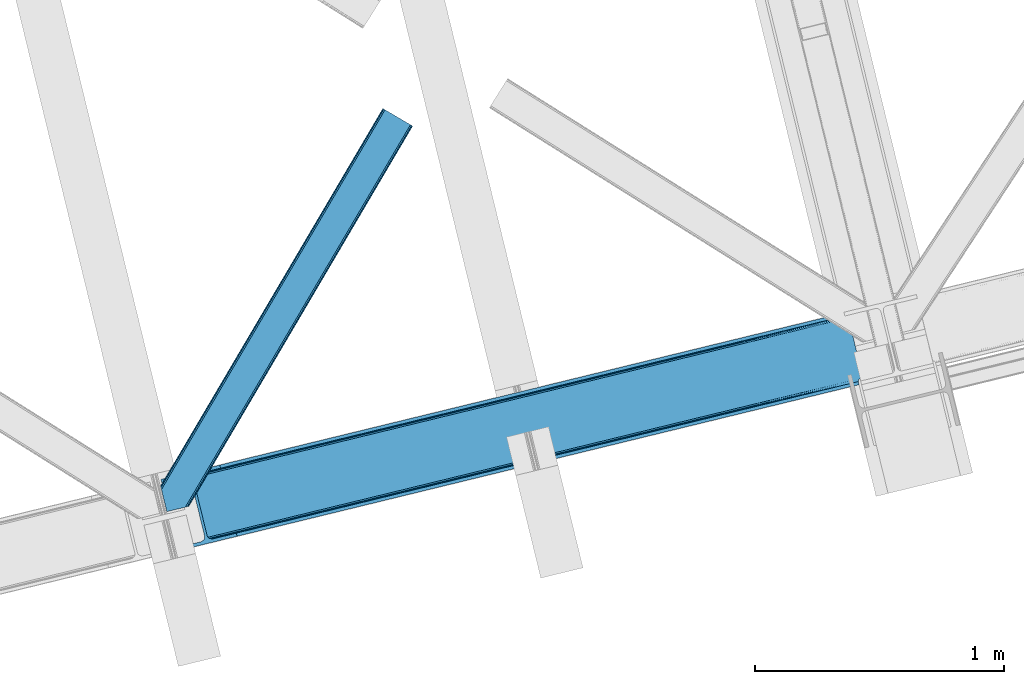
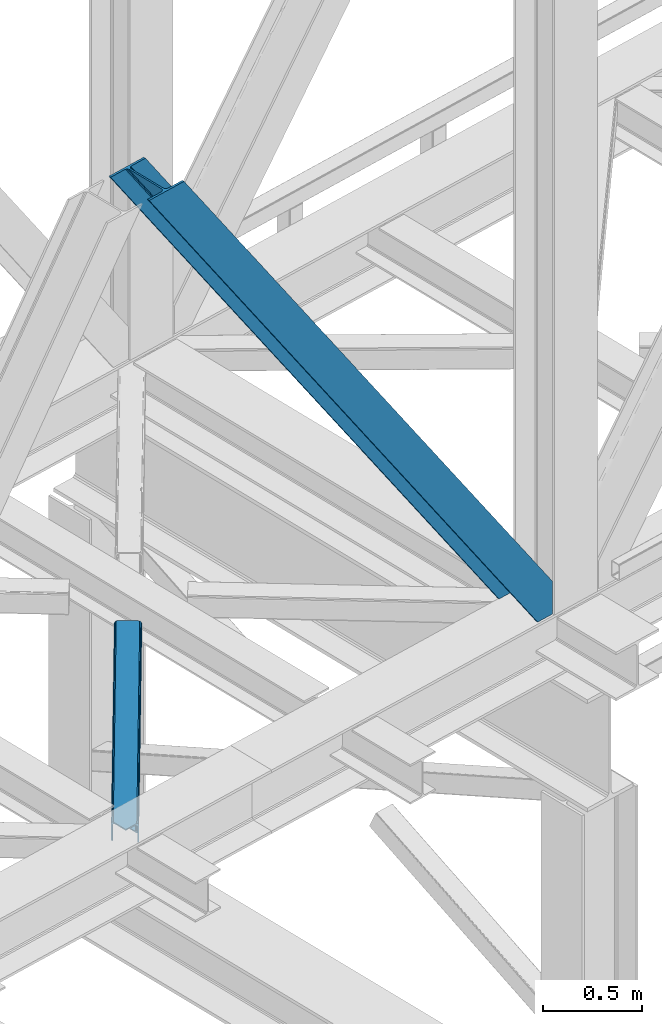
# One storey, part 35 of 92: 2 members.
"""IFC4 building model written with IfcOpenShell, lengths in millimetres."""

from ifc_helpers import new_model, entity, si_unit, converted_unit, derived_unit, direction, frame, origin, place, context, subcontext, project, spatial, triangles, type_object, element, save


model = new_model("IFC4")

# Units and contexts
model_context = context("Model", 3, precision=0.01, world=origin(), true_north=direction((6.12303176911189e-17, 1.0)))
plan_context = context("Plan", 3, precision=0.01, world=origin(), true_north=direction((6.12303176911189e-17, 1.0)))
body_context = subcontext(model_context, "Body", "Model", "MODEL_VIEW")
ifc_project = project(units=[si_unit("LENGTHUNIT", "METRE", prefix="MILLI"), si_unit("AREAUNIT", "SQUARE_METRE"), si_unit("VOLUMEUNIT", "CUBIC_METRE"), converted_unit("PLANEANGLEUNIT", "DEGREE", entity("IfcRatioMeasure", 0.0174532925199433), si_unit("PLANEANGLEUNIT", "RADIAN"), dimensions=[0, 0, 0, 0, 0, 0, 0]), si_unit("MASSUNIT", "GRAM", prefix="KILO"), derived_unit("MASSDENSITYUNIT", [(si_unit("MASSUNIT", "GRAM", prefix="KILO"), 1), (si_unit("LENGTHUNIT", "METRE"), -3)]), derived_unit("MOMENTOFINERTIAUNIT", [(si_unit("LENGTHUNIT", "METRE"), 4)]), si_unit("TIMEUNIT", "SECOND"), si_unit("FREQUENCYUNIT", "HERTZ"), si_unit("THERMODYNAMICTEMPERATUREUNIT", "DEGREE_CELSIUS"), derived_unit("THERMALTRANSMITTANCEUNIT", [(si_unit("MASSUNIT", "GRAM", prefix="KILO"), 1), (si_unit("THERMODYNAMICTEMPERATUREUNIT", "KELVIN"), -1), (si_unit("TIMEUNIT", "SECOND"), -3)]), derived_unit("VOLUMETRICFLOWRATEUNIT", [(si_unit("LENGTHUNIT", "METRE"), 3), (si_unit("TIMEUNIT", "SECOND"), -1)]), derived_unit("MASSFLOWRATEUNIT", [(si_unit("MASSUNIT", "GRAM", prefix="KILO"), 1), (si_unit("TIMEUNIT", "SECOND"), -1)]), derived_unit("ROTATIONALFREQUENCYUNIT", [(si_unit("TIMEUNIT", "SECOND"), -1)]), si_unit("ELECTRICCURRENTUNIT", "AMPERE"), si_unit("ELECTRICVOLTAGEUNIT", "VOLT"), si_unit("POWERUNIT", "WATT"), si_unit("FORCEUNIT", "NEWTON", prefix="KILO"), si_unit("ILLUMINANCEUNIT", "LUX"), si_unit("LUMINOUSFLUXUNIT", "LUMEN"), si_unit("LUMINOUSINTENSITYUNIT", "CANDELA"), derived_unit("USERDEFINED", [(si_unit("MASSUNIT", "GRAM", prefix="KILO"), -1), (si_unit("LENGTHUNIT", "METRE"), -2), (si_unit("TIMEUNIT", "SECOND"), 3), (si_unit("LUMINOUSFLUXUNIT", "LUMEN"), 1)]), derived_unit("LINEARVELOCITYUNIT", [(si_unit("LENGTHUNIT", "METRE"), 1), (si_unit("TIMEUNIT", "SECOND"), -1)]), si_unit("PRESSUREUNIT", "PASCAL"), derived_unit("USERDEFINED", [(si_unit("LENGTHUNIT", "METRE"), -2), (si_unit("MASSUNIT", "GRAM", prefix="KILO"), 1), (si_unit("TIMEUNIT", "SECOND"), -2)]), derived_unit("LINEARFORCEUNIT", [(si_unit("MASSUNIT", "GRAM", prefix="KILO"), 1), (si_unit("LENGTHUNIT", "METRE"), 1), (si_unit("TIMEUNIT", "SECOND"), -2), (si_unit("LENGTHUNIT", "METRE"), -1)]), derived_unit("PLANARFORCEUNIT", [(si_unit("MASSUNIT", "GRAM", prefix="KILO"), 1), (si_unit("LENGTHUNIT", "METRE"), 1), (si_unit("TIMEUNIT", "SECOND"), -2), (si_unit("LENGTHUNIT", "METRE"), -2)])], contexts=[model_context, plan_context])

# Site, building, storey
site_placement = place(None, origin())
site = spatial("IfcSite", under=ifc_project, at=site_placement, CompositionType="ELEMENT")
building_placement = place(site_placement, origin())
building = spatial("IfcBuilding", under=site, at=building_placement, CompositionType="ELEMENT")
storey_placement = place(building_placement, frame((0.0, 0.0, 15900.0)))
storey = spatial("IfcBuildingStorey", under=building, at=storey_placement, Name="05", CompositionType="ELEMENT", Elevation=15900.0)

# Members
member_type_1 = type_object("IfcMemberType", PredefinedType="BRACE")
member_1_placement = place(storey_placement, frame((-51544.67, 4902.23, 3695.0)))
element("IfcMember", 1, at=member_1_placement, inside=storey, type_object=member_type_1, ObjectType="Steel Vertical Brace", PredefinedType="BRACE", context=body_context, shape_type="Tessellation", body=[
    triangles([(2824.16715087891, 696.209248352051, 0.781347656247817), (2824.8368774414, 695.227331542968, 1.0697021484375), (2823.33929443359, 694.862237548828, 0.0), (2821.44173583984, 702.634437561035, 0.0), (2812.37717285156, 692.190307617188, 19.5569458007813), (2812.37717285156, 692.190307617188, 0.0), (2386.756640625, 583.573681640625, 658.75048828125), (2392.34234619141, 580.919773864746, 662.07819213867), (2803.98698730469, 681.261904907226, 51.2480346679658), (2804.11256103516, 683.186206054687, 44.4996093749978), (2382.25458984375, 588.487916564942, 656.525042724606), (2808.48438720703, 690.37995300293, 26.4030395507798), (2805.01483154297, 685.663961791992, 38.2720825195283), (2805.58223876953, 687.217936706543, 34.3676696777329), (630.515002441411, 150.045492553711, 3288.98063964843), (624.69210205078, 150.036772155761, 3285.05529785156), (211.331286621098, 47.8651016235353, 3911.00081176758), (202.862036132814, 47.2110717773439, 3911.00081176758), (619.106396484378, 152.691261291504, 3281.72759399414), (195.034606933594, 49.3185012817385, 3911.00081176758), (614.608996582036, 157.60549621582, 3279.50447387695), (189.034973144531, 53.8676422119142, 3911.00081176758), (611.88358154297, 164.031266784668, 3278.7231262207), (185.784008789065, 60.1649322509766, 3911.00081176758), (2804.10325927735, 679.880593872071, 63.6403015136711), (2398.16524658203, 580.928494262695, 666.003533935545), (1956.25268554688, 473.207743835449, 1321.74955444336), (1950.42978515625, 473.198442077637, 1317.82188720703), (1508.5172241211, 365.477691650391, 1973.56790771484), (1514.34012451172, 365.486993408203, 1977.49324951172), (1066.60466308594, 257.757522583008, 2629.3116027832), (1072.42756347657, 257.766242980957, 2633.23694458008), (1944.84407958984, 475.853512573242, 1314.49418334961), (1502.93151855469, 368.132180786133, 1970.23787841797), (1061.01895751953, 260.411430358887, 2625.98389892578), (1940.3466796875, 480.767166137695, 1312.27106323242), (1498.43411865235, 373.046997070313, 1968.01475830078), (1056.52155761719, 265.326246643066, 2623.75845336914), (2379.52917480469, 594.913687133789, 655.74602050781), (1937.62126464844, 487.192936706543, 1311.48971557617), (1495.70870361328, 379.47276763916, 1967.23341064453), (1053.79614257813, 271.751435852051, 2622.97710571289), (2766.2637084961, 929.006085205078, 0.0), (2324.35114746094, 821.285334777832, 655.74602050781), (1882.43858642579, 713.564584350586, 1311.48971557617), (1440.52602539062, 605.844415283203, 1967.23341064453), (998.613464355469, 498.123083496093, 2622.97710571289), (556.705554199223, 390.402914428711, 3278.7231262207), (130.605981445311, 286.53657989502, 3911.00081176758), (303.26520996094, 70.2741989135739, 3911.00081176758), (2804.10325927735, 679.880593872071, 200.055230712889), (2807.13563232422, 667.239505004883, 200.120343017577), (2804.2939453125, 678.898095703125, 200.120343017577), (306.344091796876, 57.6441558837887, 3911.00081176758), (2807.13563232422, 667.239505004883, 0.0), (2804.2939453125, 678.898095703125, 0.0), (2803.9962890625, 682.092668151856, 0.0), (2804.11256103516, 683.186206054687, 2.42078247070094), (2804.71717529297, 685.456416320801, 5.12991943359157), (2805.58223876953, 687.217936706543, 5.67639770507594), (2807.01470947266, 689.087008666992, 4.89505004882813), (2808.48438720703, 690.37995300293, 3.35328369140552), (2811.03771972656, 691.772309875489, 0.0), (2705.51857910156, 642.469505310059, 0.0), (69.8608520507842, 0.0, 3911.00081176758), (2794.37362060547, 677.508645629883, 0.0), (2801.99641113282, 681.139819335937, 0.0), (2702.43969726563, 655.099548339844, 0.0), (66.7819702148481, 12.6300430297852, 3911.00081176758), (1480.00268554688, 357.11657409668, 1950.37164916992), (1034.28570556641, 248.469136047363, 2611.75686035156), (588.573376464847, 139.821697998047, 3273.1420715332), (158.71589355469, 35.0391403198246, 3911.00081176758), (1925.71501464844, 465.764012145996, 1288.98643798828), (2371.42734375, 574.411450195313, 627.598901367186), (2376.60377197266, 577.083380126953, 631.526568603513), (2380.33842773438, 582.010404968261, 634.854272460936), (2381.53370361328, 595.402029418945, 637.858740234373), (2811.39118652344, 700.184587097168, 0.0), (2811.09353027344, 693.083276367188, 0.0), (2382.0732055664, 588.443151855468, 637.077392578125), (598.679736328129, 160.812277221679, 3283.40191040039), (599.21923828125, 153.853399658203, 3282.62056274414), (175.733459472656, 57.7150817871097, 3911.00081176758), (175.747412109376, 50.6277236938477, 3911.00081176758), (597.484460449217, 147.420652770996, 3280.39744262695), (172.515051269533, 43.8298828124998, 3911.00081176758), (593.749804687504, 142.493627929687, 3277.06973876953), (166.534020996092, 38.3557983398441, 3911.00081176758), (1935.82137451172, 486.754591369629, 1299.24395141601), (1936.36087646485, 479.795713806152, 1298.46260375976), (1490.10904541016, 378.107153320312, 1960.63148803711), (1490.64389648438, 371.148275756836, 1959.85014038086), (1044.93156738282, 262.500837707519, 2621.2353515625), (1044.39206542969, 269.459715270996, 2622.01669921875), (1934.62609863281, 473.362966918945, 1296.23948364258), (1488.91376953125, 364.715528869629, 1957.62469482422), (1043.20144042969, 256.068090820312, 2619.01223144531), (1930.88679199219, 468.435360717774, 1292.91177978515), (1485.17446289062, 359.78850402832, 1954.2969909668), (1039.46213378906, 251.141065979004, 2615.68220214844), (2756.21315917969, 926.556234741211, 0.0), (2326.35567626953, 821.773677062988, 637.858740234373), (1434.9263671875, 604.478800964355, 1960.63148803711), (1880.63869628906, 713.126239013672, 1299.24395141601), (989.214038085942, 495.831362915039, 2622.01669921875), (543.501708984375, 387.183924865722, 3283.40191040039), (120.555432128909, 284.086729431152, 3911.00081176758), (2752.67849121094, 932.723300170898, 0.0), (2753.40867919922, 934.106936645508, 0.0), (2752.02736816406, 933.862184143067, 0.0), (2764.36614990234, 936.778285217285, 0.0), (2753.40867919922, 934.106936645508, 19.5569458007813), (2765.86373291015, 937.143960571289, 1.0697021484375), (2765.72420654297, 935.965544128418, 0.781347656247817), (2325.54642333985, 834.677540588379, 658.75048828125), (2749.12056884765, 933.923226928711, 26.4030395507798), (2745.08825683594, 935.394648742676, 34.3676696777329), (2323.81164550781, 828.244212341308, 656.525042724606), (2743.50695800781, 936.560275268555, 38.5441589355469), (556.166052246095, 397.361791992187, 3279.50447387695), (130.592028808598, 293.623937988281, 3911.00081176758), (557.896179199219, 403.794538879394, 3281.72759399414), (133.824389648442, 300.422360229492, 3911.00081176758), (561.635485839848, 408.721563720703, 3285.05529785156), (139.805419921875, 305.895863342285, 3911.00081176758), (566.807263183597, 411.393493652344, 3288.98063964843), (147.623547363284, 309.212521362305, 3911.00081176758), (2740.92572021484, 939.947277832031, 51.2480346679658), (2740.39552001953, 941.22801361084, 63.6403015136711), (2329.28572998047, 839.604565429688, 662.07819213867), (2334.45750732422, 842.275914001465, 666.003533935545), (2742.08843994141, 938.421208190918, 45.5251281738274), (1881.89908447266, 720.523461914063, 1312.27106323242), (1439.9911743164, 612.80329284668, 1968.01475830078), (998.07861328125, 505.082542419434, 2623.75845336914), (1883.63386230469, 726.956790161133, 1314.49418334961), (1441.72130126954, 619.235458374023, 1970.23787841797), (999.808740234374, 511.515289306641, 2625.98389892578), (1887.36851806641, 731.883815002441, 1317.82188720703), (1445.46060791016, 624.163064575196, 1973.56790771484), (1003.548046875, 516.442314147949, 2629.3116027832), (1892.54494628906, 734.555163574219, 1321.74955444336), (1450.63238525391, 626.834413146973, 1977.49324951172), (1008.71982421875, 519.11424407959, 2633.23694458008), (2740.39552001953, 941.22801361084, 200.055230712889), (239.557470703126, 331.622200012207, 3911.00081176758), (2749.12056884765, 933.923226928711, 3.35328369140552), (2745.08825683594, 935.394648742676, 5.67639770507594), (2747.22301025391, 934.392384338379, 4.89272460937354), (2743.50695800781, 936.560275268555, 5.12991943359157), (2740.11646728516, 942.189001464843, 0.0), (2741.92565917969, 938.297378540039, 2.42078247070094), (2740.11646728516, 942.189001464843, 200.120343017577), (2741.32104492188, 939.215927124023, 0.0), (2323.63026123047, 828.199447631836, 637.077392578125), (2319.13286132813, 833.113682556153, 634.854272460936), (2313.54715576172, 835.768171691894, 631.526568603513), (2307.71960449219, 835.758869934082, 627.598901367186), (2730.66588134766, 938.856065368653, 0.0), (2739.1072265625, 939.140931701661, 0.0), (524.865637207033, 401.169117736817, 3273.1420715332), (530.688537597656, 401.178419494629, 3277.06973876953), (103.477404785161, 297.041171264648, 3911.00081176758), (95.0081542968765, 296.386560058594, 3911.00081176758), (536.274243164065, 398.523930358887, 3280.39744262695), (111.304833984374, 294.933160400391, 3911.00081176758), (540.776293945317, 393.60969543457, 3282.62056274414), (117.304467773436, 290.384019470215, 3911.00081176758), (1867.83017578125, 727.120733642578, 1292.91177978515), (1862.00727539063, 727.111431884766, 1288.98643798828), (1422.11784667969, 618.473295593261, 1954.2969909668), (1416.29494628906, 618.463993835449, 1950.37164916992), (976.405517578125, 509.825857543945, 2615.68220214844), (970.582617187501, 509.816555786133, 2611.75686035156), (1873.41588134766, 724.466244506836, 1296.23948364258), (1427.70355224609, 615.81880645752, 1957.62469482422), (981.991223144534, 507.171368408203, 2619.01223144531), (1877.9179321289, 719.55200958252, 1298.46260375976), (1432.20095214844, 610.904571533203, 1959.85014038086), (986.488623046876, 502.257133483887, 2621.2353515625), (2737.27478027344, 953.847592163086, 200.120343017577), (236.47858886719, 344.252243041992, 3911.00081176758), (2737.27478027344, 953.847592163086, 0.0), (0.0, 286.60750579834, 3911.00081176758), (3.07888183593604, 273.977462768555, 3911.00081176758), (2635.65772705078, 929.077011108398, 0.0), (2638.73660888672, 916.446968078613, 0.0)], [[1, 2, 3], [3, 4, 1], [2, 5, 6], [6, 3, 2], [7, 8, 9], [9, 10, 7], [11, 12, 5], [5, 1, 11], [5, 2, 1], [11, 7, 13], [13, 14, 11], [14, 12, 11], [15, 16, 17], [18, 17, 16], [16, 19, 18], [20, 18, 19], [19, 21, 20], [22, 20, 21], [21, 23, 22], [24, 22, 23], [10, 13, 7], [25, 9, 8], [8, 26, 25], [26, 8, 27], [28, 27, 8], [27, 28, 29], [29, 30, 27], [30, 29, 31], [31, 32, 30], [32, 31, 15], [16, 15, 31], [8, 7, 33], [33, 28, 8], [28, 33, 29], [34, 29, 33], [29, 34, 31], [35, 31, 34], [31, 35, 19], [19, 16, 31], [7, 11, 36], [36, 33, 7], [33, 36, 37], [37, 34, 33], [34, 37, 35], [38, 35, 37], [35, 38, 19], [21, 19, 38], [1, 4, 39], [39, 11, 1], [11, 39, 36], [40, 36, 39], [36, 40, 37], [41, 37, 40], [37, 41, 42], [42, 38, 37], [38, 42, 21], [23, 21, 42], [4, 43, 44], [45, 39, 44], [41, 40, 45], [41, 45, 46], [44, 39, 4], [45, 40, 39], [42, 41, 46], [46, 47, 42], [47, 48, 23], [49, 24, 48], [47, 23, 42], [48, 24, 23], [50, 51, 30], [30, 32, 50], [32, 15, 50], [17, 50, 15], [27, 30, 51], [51, 25, 26], [26, 27, 51], [52, 53, 54], [53, 51, 50], [50, 54, 53], [52, 55, 53], [56, 53, 55], [56, 9, 25], [56, 57, 58], [58, 10, 56], [10, 9, 56], [59, 60, 14], [14, 13, 59], [10, 58, 59], [60, 61, 12], [12, 14, 60], [5, 62, 63], [63, 6, 5], [5, 12, 62], [61, 62, 12], [13, 10, 59], [25, 51, 53], [53, 56, 25], [54, 64, 52], [54, 65, 64], [64, 55, 52], [56, 66, 67], [55, 66, 56], [67, 57, 56], [64, 66, 55], [64, 68, 66], [68, 64, 65], [65, 69, 68], [69, 70, 68], [71, 69, 72], [69, 71, 70], [69, 73, 72], [74, 68, 70], [66, 68, 75], [74, 75, 68], [67, 76, 58], [76, 77, 59], [59, 58, 76], [76, 67, 66], [78, 79, 80], [81, 60, 59], [81, 80, 62], [62, 61, 81], [61, 60, 81], [80, 63, 62], [59, 77, 81], [80, 81, 78], [82, 83, 84], [85, 84, 83], [83, 86, 85], [87, 85, 86], [86, 88, 87], [89, 87, 88], [88, 72, 89], [73, 89, 72], [66, 75, 76], [58, 57, 67], [78, 81, 90], [91, 90, 81], [90, 91, 92], [93, 92, 91], [92, 93, 94], [94, 95, 92], [95, 94, 83], [83, 82, 95], [81, 77, 96], [96, 91, 81], [91, 96, 93], [97, 93, 96], [93, 97, 98], [98, 94, 93], [94, 98, 83], [86, 83, 98], [77, 76, 99], [99, 96, 77], [96, 99, 100], [100, 97, 96], [97, 100, 101], [101, 98, 97], [98, 101, 88], [88, 86, 98], [76, 75, 99], [74, 99, 75], [99, 74, 100], [70, 100, 74], [100, 70, 101], [71, 101, 70], [101, 71, 88], [72, 88, 71], [102, 79, 78], [90, 103, 78], [104, 105, 90], [104, 90, 92], [78, 103, 102], [90, 105, 103], [106, 104, 92], [92, 95, 106], [95, 82, 107], [84, 108, 82], [95, 107, 106], [82, 108, 107], [109, 102, 110], [6, 79, 80], [6, 80, 63], [110, 111, 109], [3, 79, 6], [79, 4, 102], [3, 4, 79], [43, 102, 4], [102, 112, 110], [112, 102, 43], [113, 114, 110], [112, 110, 114], [114, 115, 112], [43, 112, 115], [116, 117, 118], [119, 115, 113], [113, 116, 119], [113, 117, 116], [115, 114, 113], [118, 120, 116], [48, 121, 122], [122, 49, 48], [121, 123, 124], [124, 122, 121], [123, 125, 126], [126, 124, 123], [125, 127, 128], [128, 126, 125], [129, 130, 131], [132, 131, 130], [133, 116, 120], [116, 133, 129], [131, 116, 129], [43, 115, 119], [119, 44, 43], [44, 119, 134], [134, 45, 44], [45, 134, 135], [135, 46, 45], [46, 135, 47], [136, 47, 135], [47, 136, 121], [121, 48, 47], [119, 116, 134], [137, 134, 116], [134, 137, 135], [138, 135, 137], [135, 138, 139], [139, 136, 135], [136, 139, 123], [123, 121, 136], [116, 131, 137], [140, 137, 131], [137, 140, 141], [141, 138, 137], [138, 141, 142], [142, 139, 138], [139, 142, 123], [125, 123, 142], [131, 132, 143], [143, 140, 131], [140, 143, 141], [144, 141, 143], [141, 144, 142], [145, 142, 144], [142, 145, 127], [127, 125, 142], [144, 146, 147], [147, 127, 145], [127, 147, 128], [145, 144, 147], [146, 144, 143], [143, 132, 146], [130, 146, 132], [113, 110, 111], [148, 117, 113], [149, 118, 117], [117, 148, 150], [151, 133, 120], [118, 149, 151], [151, 120, 118], [152, 133, 153], [152, 129, 133], [146, 130, 154], [152, 154, 130], [130, 129, 152], [153, 155, 152], [151, 153, 133], [117, 150, 149], [111, 148, 113], [156, 150, 148], [156, 149, 150], [148, 109, 156], [148, 111, 109], [156, 157, 151], [151, 149, 156], [103, 156, 109], [158, 159, 160], [158, 153, 151], [158, 161, 153], [161, 155, 153], [151, 157, 158], [160, 161, 158], [162, 163, 164], [164, 165, 162], [163, 166, 167], [167, 164, 163], [166, 168, 169], [169, 167, 166], [168, 107, 108], [108, 169, 168], [109, 102, 103], [159, 158, 170], [170, 171, 159], [171, 170, 172], [172, 173, 171], [173, 172, 174], [174, 175, 173], [175, 174, 163], [163, 162, 175], [158, 157, 170], [176, 170, 157], [170, 176, 172], [177, 172, 176], [172, 177, 174], [178, 174, 177], [174, 178, 163], [166, 163, 178], [157, 156, 176], [179, 176, 156], [176, 179, 180], [180, 177, 176], [177, 180, 178], [181, 178, 180], [178, 181, 168], [168, 166, 178], [156, 103, 105], [105, 179, 156], [179, 105, 104], [104, 180, 179], [180, 104, 106], [106, 181, 180], [181, 106, 168], [107, 168, 106], [146, 154, 147], [154, 182, 183], [183, 147, 154], [154, 152, 184], [184, 182, 154], [108, 84, 49], [87, 89, 18], [73, 65, 54], [69, 65, 73], [89, 73, 17], [84, 85, 22], [85, 87, 20], [167, 126, 164], [185, 165, 183], [165, 164, 128], [185, 186, 165], [167, 169, 124], [169, 108, 122], [49, 84, 24], [17, 18, 89], [22, 85, 20], [18, 20, 87], [22, 24, 84], [54, 17, 73], [54, 50, 17], [128, 164, 126], [124, 169, 122], [49, 122, 108], [124, 126, 167], [128, 183, 165], [183, 128, 147], [152, 160, 184], [155, 161, 152], [152, 161, 160], [160, 187, 184], [187, 160, 188], [183, 187, 185], [187, 183, 182], [184, 187, 182], [173, 186, 188], [162, 186, 175], [162, 165, 186], [173, 175, 186], [188, 171, 173], [159, 171, 188], [188, 160, 159], [187, 188, 185], [186, 185, 188]]),
])
member_type_2 = type_object("IfcMemberType", PredefinedType="BRACE")
member_2_placement = place(storey_placement, frame((-51546.08, 5059.05, 3511.0)))
element("IfcMember", 2, at=member_2_placement, inside=storey, type_object=member_type_2, ObjectType="Steel Horizontal Brace", PredefinedType="BRACE", context=body_context, shape_type="Tessellation", body=[
    triangles([(154.446386718751, 124.70924835205, 0.0), (118.769494628912, 271.071826171875, 0.0), (998.971582031256, 1559.19901428223, 0.0), (908.484082031253, 1612.46901855469, 0.0), (1004.73867187501, 1555.80154724121, 1.33247680664135), (156.720666503912, 115.37377166748, 1.33247680664135), (1009.63604736328, 1552.92090911865, 5.12526855468968), (158.650781250006, 107.459719848633, 5.12526855468968), (1012.90096435547, 1550.99602661133, 10.8028289794929), (159.939074707036, 102.17225189209, 10.8028289794929), (1014.04973144532, 1550.32048645019, 17.5000946044929), (160.39020996094, 100.315388488769, 17.5000946044929), (902.716992187503, 1615.8664855957, 1.33247680664135), (116.495214843751, 280.406721496582, 1.33247680664135), (114.574401855469, 288.276008605957, 5.17061462402489), (897.824267578129, 1618.74712371826, 5.12526855468968), (114.495336914064, 288.596919250488, 5.32641906738354), (894.554699707034, 1620.67142486572, 10.8028289794929), (109.625866699222, 287.409201049804, 10.8028289794929), (893.405932617192, 1621.34754638672, 17.5000946044929), (107.821325683595, 286.969692993163, 17.5000946044929), (113.523303222661, 288.360305786133, 18.5197998046897), (114.495336914064, 288.596919250488, 17.5198608398459), (114.420922851568, 288.578897094726, 17.9023956298843), (114.211633300787, 288.527737426757, 18.2279571533218), (113.895373535161, 288.450416564941, 18.4442230224631), (107.821325683595, 286.969692993163, 18.5197998046897), (115.695263671878, 283.683847045898, 17.5198608398459), (115.625500488284, 283.800700378418, 17.8035644531265), (115.565039062501, 283.7408203125, 17.8570495605491), (115.318542480469, 283.496067810058, 18.0768035888686), (115.067395019534, 283.239688110351, 18.3081848144539), (114.830200195313, 283.003656005859, 18.5197998046897), (0.0, 103.825057983398, 18.5197998046897), (2.73471679687646, 92.5989990234375, 18.5197998046897), (893.405932617192, 1621.34754638672, 122.500662231447), (0.0, 103.825057983398, 122.500662231447), (908.484082031253, 1612.46901855469, 139.999594116212), (902.716992187503, 1615.8664855957, 138.667117309571), (3.66954345703562, 88.766093444824, 138.667117309571), (5.94382324218896, 79.4311981201172, 139.999594116212), (897.824267578129, 1618.74712371826, 134.874325561526), (1.73942871094187, 96.6801452636719, 134.874325561526), (894.554699707034, 1620.67142486572, 129.197927856447), (0.451135253912071, 101.968194580078, 129.197927856447), (899.438122558597, 1617.79601898193, 24.4996673583992), (2.37659912109666, 94.0675140380854, 24.4996673583992), (900.586889648439, 1617.1204788208, 17.8035644531265), (903.856457519534, 1615.19559631348, 12.1260040283232), (914.516271972658, 1608.9174911499, 6.99957275390625), (908.749182128908, 1612.31553955078, 8.3320495605476), (118.871813964848, 270.64917755127, 8.3320495605476), (121.146093750001, 261.314282226562, 6.99957275390625), (116.941699218754, 278.563229370116, 12.1260040283232), (152.069787597662, 134.466792297363, 6.99957275390625), (992.939392089844, 1562.75054168701, 6.99957275390625), (156.274182128909, 117.217263793945, 12.1260040283232), (154.344067382815, 125.131315612793, 8.3320495605476), (157.520617675786, 112.097227478027, 17.5198608398459), (160.39020996094, 100.315388488769, 17.5198608398459), (899.438122558597, 1617.79601898193, 115.501089477541), (2.37659912109666, 94.0675140380854, 115.501089477541), (900.586889648439, 1617.1204788208, 122.196029663086), (2.82773437500146, 92.2106506347654, 122.196029663086), (903.856457519534, 1615.19559631348, 127.87475280762), (4.12067871094041, 86.9226013183588, 127.87475280762), (908.749182128908, 1612.31553955078, 131.667544555665), (6.046142578125, 79.008549499511, 131.667544555665), (914.516271972658, 1608.9174911499, 133.000021362306), (8.3250732421875, 69.6736541748041, 133.000021362306), (25.3054321289092, 0.0, 133.000021362306), (25.3054321289092, 0.0, 139.999594116212), (90.3619262695356, 15.8583343505852, 139.999594116212), (998.971582031256, 1559.19901428223, 139.999594116212), (1014.04973144532, 1550.32048645019, 122.500662231447), (1012.90096435547, 1550.99602661133, 129.197927856447), (114.0721069336, 21.6382141113281, 122.500662231447), (112.267565917973, 21.1981246948235, 129.197927856447), (1009.63604736328, 1552.92090911865, 134.874325561526), (107.128344726567, 19.9452941894524, 134.874325561526), (1004.73867187501, 1555.80154724121, 138.667117309571), (99.435791015625, 18.0698272705076, 138.667117309571), (159.664672851563, 99.0788360595698, 18.5197998046897), (114.0721069336, 21.6382141113281, 18.5197998046897), (103.161145019534, 18.9784927368164, 18.5197998046897), (156.929956054693, 110.304895019531, 18.5197998046897), (1008.01754150391, 1553.87201385498, 24.4996673583992), (1006.86877441406, 1554.54755401611, 17.8035644531265), (157.222961425781, 111.200770568847, 18.0198303222678), (1003.60385742188, 1556.47243652344, 12.1260040283232), (998.706481933594, 1559.35249328613, 8.3320495605476), (104.588964843751, 19.3261459350579, 24.4996673583992), (1003.60385742188, 1556.47243652344, 127.87475280762), (1008.01754150391, 1553.87201385498, 115.501089477541), (1006.86877441406, 1554.54755401611, 122.196029663086), (992.939392089844, 1562.75054168701, 133.000021362306), (998.706481933594, 1559.35249328613, 131.667544555665), (102.784423828125, 18.8860565185541, 122.196029663086), (80.8787841796875, 13.5468475341795, 133.000021362306), (89.9526489257842, 15.758340454101, 131.667544555665), (97.6452026367188, 17.633226013183, 127.87475280762), (104.588964843751, 19.3261459350579, 115.501089477541)], [[1, 2, 3], [4, 3, 2], [3, 5, 1], [6, 1, 5], [5, 7, 6], [8, 6, 7], [7, 9, 8], [10, 8, 9], [9, 11, 10], [12, 10, 11], [13, 14, 15], [16, 15, 17], [17, 18, 16], [17, 19, 18], [20, 18, 19], [19, 21, 20], [15, 16, 13], [13, 4, 14], [2, 14, 4], [22, 23, 24], [22, 25, 26], [27, 21, 22], [24, 25, 22], [23, 22, 21], [21, 19, 23], [17, 23, 19], [23, 28, 29], [29, 24, 23], [25, 24, 30], [26, 25, 31], [22, 26, 32], [32, 33, 22], [31, 32, 26], [30, 31, 25], [29, 30, 24], [34, 33, 35], [33, 34, 27], [22, 33, 27], [27, 20, 21], [36, 27, 37], [27, 36, 20], [27, 34, 37], [38, 39, 40], [40, 41, 38], [39, 42, 43], [43, 40, 39], [42, 44, 45], [45, 43, 42], [44, 36, 37], [37, 45, 44], [46, 47, 33], [33, 48, 46], [33, 31, 48], [47, 35, 33], [49, 48, 28], [50, 51, 52], [52, 53, 50], [51, 49, 54], [54, 52, 51], [28, 54, 49], [53, 55, 56], [56, 50, 53], [55, 2, 1], [54, 17, 14], [52, 14, 2], [52, 2, 53], [55, 53, 2], [17, 28, 23], [54, 28, 17], [52, 54, 14], [57, 58, 6], [58, 1, 6], [1, 58, 55], [8, 57, 6], [8, 59, 57], [10, 59, 8], [10, 60, 59], [46, 61, 47], [62, 47, 61], [61, 63, 62], [64, 62, 63], [63, 65, 64], [66, 64, 65], [65, 67, 66], [68, 66, 67], [67, 69, 68], [70, 68, 69], [66, 43, 64], [71, 72, 70], [72, 41, 70], [40, 68, 41], [66, 68, 40], [68, 70, 41], [66, 40, 43], [37, 34, 62], [45, 64, 43], [62, 64, 37], [64, 45, 37], [34, 47, 62], [34, 35, 47], [41, 73, 74], [73, 41, 72], [74, 38, 41], [75, 76, 77], [78, 77, 76], [76, 79, 78], [80, 78, 79], [79, 81, 80], [82, 80, 81], [81, 74, 82], [73, 82, 74], [60, 75, 77], [60, 11, 75], [77, 83, 60], [77, 84, 83], [84, 85, 83], [86, 83, 85], [87, 88, 59], [89, 86, 87], [88, 90, 57], [57, 59, 88], [90, 91, 58], [58, 57, 90], [91, 56, 55], [55, 58, 91], [87, 86, 92], [85, 92, 86], [9, 90, 88], [87, 75, 11], [9, 88, 11], [9, 7, 90], [88, 87, 11], [90, 7, 5], [56, 3, 4], [3, 91, 5], [91, 3, 56], [91, 90, 5], [76, 93, 79], [94, 75, 87], [75, 95, 76], [95, 75, 94], [76, 95, 93], [74, 96, 38], [81, 79, 93], [93, 97, 81], [97, 96, 74], [74, 81, 97], [49, 13, 16], [4, 50, 56], [4, 51, 50], [51, 4, 13], [49, 51, 13], [46, 20, 36], [18, 48, 49], [16, 18, 49], [48, 18, 20], [46, 48, 20], [39, 65, 42], [38, 96, 69], [69, 67, 38], [67, 65, 39], [39, 38, 67], [44, 42, 65], [36, 61, 46], [63, 36, 44], [36, 63, 61], [63, 44, 65], [98, 78, 80], [99, 73, 72], [72, 71, 99], [99, 100, 73], [100, 82, 73], [101, 82, 100], [80, 82, 101], [98, 77, 78], [102, 77, 98], [80, 101, 98], [84, 92, 85], [102, 84, 77], [92, 84, 102], [99, 70, 96], [99, 71, 70], [69, 96, 70], [96, 97, 100], [100, 99, 96], [97, 93, 101], [101, 100, 97], [93, 95, 98], [98, 101, 93], [95, 94, 102], [102, 98, 95], [94, 87, 92], [92, 102, 94]]),
])

save(model, "model.ifc")
